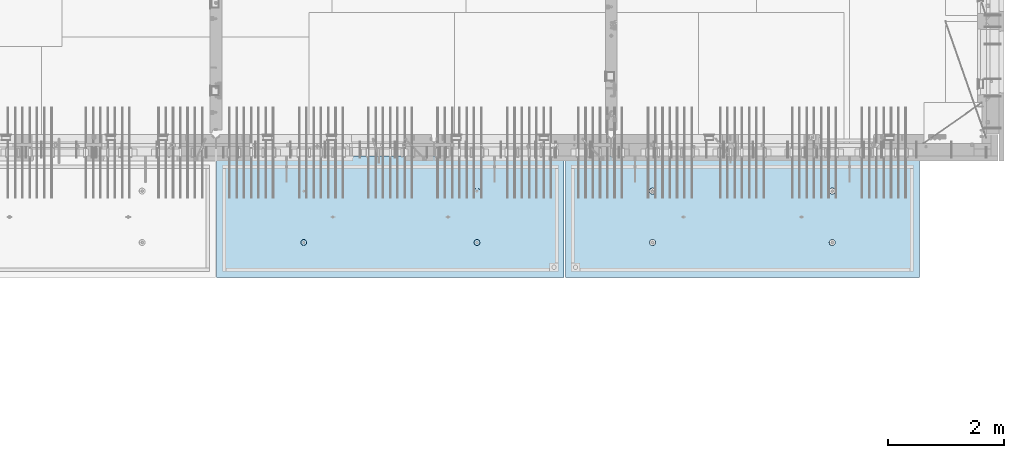
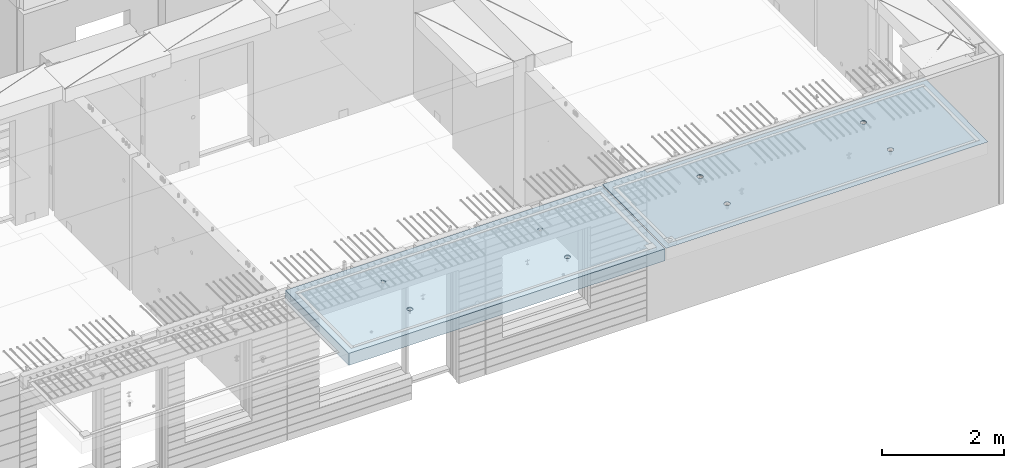
# One storey, part 195 of 334: 2 slabs, 2 elements without a shape of their own.
"""IFC2X3 building model written with IfcOpenShell, lengths in millimetres."""

from ifc_helpers import new_model, si_unit, frame, origin_with_axes, place, context, subcontext, project, spatial, faceted_brep, material, type_object, element, aggregate, save


model = new_model("IFC2X3")

# Units and contexts
model_context = context("Model", 3, precision=1e-05, world=origin_with_axes())
body_context = subcontext(model_context, "Body", "Model", "MODEL_VIEW")
ifc_project = project(units=[si_unit("LENGTHUNIT", "METRE", prefix="MILLI"), si_unit("AREAUNIT", "SQUARE_METRE"), si_unit("VOLUMEUNIT", "CUBIC_METRE"), si_unit("MASSUNIT", "GRAM", prefix="KILO"), si_unit("TIMEUNIT", "SECOND"), si_unit("PLANEANGLEUNIT", "RADIAN"), si_unit("SOLIDANGLEUNIT", "STERADIAN"), si_unit("THERMODYNAMICTEMPERATUREUNIT", "DEGREE_CELSIUS"), si_unit("LUMINOUSINTENSITYUNIT", "LUMEN")], contexts=[model_context])

# Site, building, storey
site_placement = place(None, origin_with_axes())
site = spatial("IfcSite", under=ifc_project, at=site_placement, CompositionType="ELEMENT")
building_placement = place(site_placement, origin_with_axes())
building = spatial("IfcBuilding", under=site, at=building_placement, CompositionType="ELEMENT")
storey_placement = place(building_placement, origin_with_axes())
storey = spatial("IfcBuildingStorey", under=building, at=storey_placement, Name="3", CompositionType="ELEMENT", Elevation=0.0)

# Assembly, slab
assembly_1_placement = place(storey_placement, origin_with_axes())
assembly_1 = element("IfcElementAssembly", 1, at=assembly_1_placement, inside=storey, AssemblyPlace="NOTDEFINED", PredefinedType="REINFORCEMENT_UNIT")
ifc_material = material(Name="CONCRETE/C35/45")
slab_type_1 = type_object("IfcSlabType", PredefinedType="NOTDEFINED")
slab_1_placement = place(assembly_1_placement, frame((33909.9998568133, 7629.99655735226, 90720.0), z_axis=(-1.11800000013248e-06, -0.999999999999375, 0.0), x_axis=(-0.999999999999093, 1.34699999998405e-06, 0.0)))
slab_1 = element("IfcSlab", 2, at=slab_1_placement, type_object=slab_type_1, material=ifc_material, PredefinedType="FLOOR", context=body_context, shape_type="Brep", body=[
    faceted_brep([(4540.5429407651, 4.39872694581572, 1501.06992058926), (4541.14829635528, 10.0, 1500.87322939105), (4548.44394652849, 10.0, 1515.19178906455), (4547.94177529477, 4.5376880098047, 1515.55663695519), (4559.80720044041, 10.0, 1526.55506865745), (4559.44971344555, 4.64790814399021, 1527.04710612474), (4574.1257436257, 10.0, 1533.85075119058), (4573.94028523447, 4.71864591048507, 1534.42153123348), (4589.99797731422, 10.0, 1536.36468442559), (4589.99797663917, 4.74301553473924, 1536.96206902392), (4605.87021668419, 10.0, 1533.85078706184), (4606.05567377324, 4.71864625823218, 1534.42156748629), (4620.18877635769, 10.0, 1526.55513688863), (4620.54626219634, 4.64790880566579, 1527.04717510301), (4631.55205595059, 10.0, 1515.19188297671), (4632.05422627598, 4.53768892097287, 1515.5567319414), (4638.84773848372, 10.0, 1500.87333979142), (4639.45309351355, 4.39872801757883, 1501.0700323201), (4641.36167171873, 10.0, 1485.0011061029), (4642.01569559209, 4.24458991442225, 1485.00110684195), (4638.84777435497, 10.0, 1469.12886673293), (4639.48645790269, 4.09034788147255, 1468.92134666652), (4631.55212418177, 10.0, 1454.81030705943), (4632.10822132771, 3.95111487063696, 1454.40627979329), (4620.18887026985, 10.0, 1443.44702746653), (4620.60028327593, 3.84055859092041, 1442.88076738872), (4605.87032708456, 10.0, 1436.1513449334), (4606.0891136727, 3.76954887632746, 1435.47799164192), (4589.99809339604, 10.0, 1433.63741169839), (4589.99809419923, 3.74507537655882, 1432.92662480936), (4574.12585402606, 10.0, 1436.15130906214), (4573.90706894744, 3.76954852712515, 1435.47795523847), (4559.80729435257, 10.0, 1443.44695923535), (4559.39588258188, 3.84055792690197, 1442.8806981667), (4548.44401475967, 10.0, 1454.81021314727), (4547.88791844284, 3.95111395715503, 1454.40618456334), (4541.14833222653, 10.0, 1469.12875633256), (4540.50964903182, 4.09034680826881, 1468.92123478504), (4538.63439899152, 10.0, 1485.00099002108), (4537.98037499001, 4.24458878673613, 1485.00098928203), (0.0, 10.0, 0.0), (0.0, -10.0, 0.0), (0.000819232023786753, 10.0, 2085.00366210937), (6090.0, 10.0, 1.39971234602854e-09), (6090.0, -10.0, 1.39971234602854e-09), (6090.0009765625, 10.0, 2085.00366210937), (1450.13343574908, -4.39996016312216, 583.805178487186), (1451.68970517172, 10.0, 584.310843019489), (1449.20358093267, 10.0, 600.007498901724), (1447.58488291994, -4.2445425120095, 600.007497072595), (1457.56794425657, -4.54025428339082, 569.17949076172), (1458.90468325205, 10.0, 570.15069079864), (1469.16362510388, -4.65165300057561, 557.566154097598), (1470.14226284945, 10.0, 558.913136598135), (1483.78541952188, -4.72320365252381, 550.106985529351), (1484.30243137612, 10.0, 551.698190519764), (1499.99909477071, -4.74786334385863, 547.536208193364), (1499.99909287695, 10.0, 549.212101755165), (1516.2127641972, -4.72320330067305, 550.107022210277), (1515.69574875919, 10.0, 551.698225994214), (1530.8345417251, -4.65165233150765, 557.566223847243), (1529.85590098004, 10.0, 558.913204074546), (1542.4301962863, -4.54025336292398, 569.179586717545), (1541.09345518054, 10.0, 570.150783671952), (1549.86467170747, -4.39995908172568, 583.805291221456), (1548.30840125891, 10.0, 584.310952198615), (1552.41318790712, -4.24454137573775, 600.00761552858), (1550.79449002351, 10.0, 600.007613699451), (1549.83105300624, -4.08922839167644, 616.199022553535), (1548.30836578447, 10.0, 615.704269581685), (1542.37578967018, -3.94920829200419, 630.796143582923), (1541.09338770413, 10.0, 629.864421802535), (1530.78010888273, -3.83814828256436, 642.374169903326), (1529.85580810672, 10.0, 641.101976003039), (1516.17906941009, -3.76687165064504, 649.804771831361), (1515.69563958006, 10.0, 648.316922081409), (1499.99897631459, -3.74231662515376, 652.364637735232), (1499.99897807923, 10.0, 650.803010846011), (1483.81888899212, -3.76687200104061, 649.804735302227), (1484.30232219699, 10.0, 648.316886606961), (1469.21786628045, -3.83814894927491, 642.374100399286), (1470.14216997614, 10.0, 641.101908526629), (1457.62221161949, -3.94920921009907, 630.796047872702), (1458.90461577564, 10.0, 629.864328929222), (1450.16698124064, -4.08922947161773, 616.198909971055), (1451.68966969727, 10.0, 615.704160402559), (1450.509655854, 4.09040925785666, 1468.92774521603), (1451.1483322995, 10.0, 1469.13526457059), (1448.63439906449, 10.0, 1485.00749825911), (1447.98038215714, 4.24465121529647, 1485.00749752007), (1457.88792425878, 3.95117642574769, 1454.41269697389), (1458.44401483263, 10.0, 1454.8167213853), (1469.39588682837, 3.84062041057041, 1442.8872121491), (1469.80729442553, 10.0, 1443.45346747338), (1483.90707121489, 3.76961102048517, 1435.48447023045), (1484.12585409903, 10.0, 1436.15781730018), (1499.99809427218, 3.74513787325122, 1432.93314014929), (1499.998093469, 10.0, 1433.64391993642), (1516.08911155117, 3.76961136968748, 1435.48450663389), (1515.87032715752, 10.0, 1436.15785317143), (1530.60027917537, 3.8406210745743, 1442.88728137111), (1530.18887034281, 10.0, 1443.45353570456), (1542.1082156577, 3.95117733922962, 1454.41279220383), (1541.55212425473, 10.0, 1454.81681529746), (1549.48645122644, 4.09041033107496, 1468.92785709749), (1548.84777442794, 10.0, 1469.13537497096), (1552.0156885709, 4.24465234298259, 1485.00761507997), (1551.3616717917, 10.0, 1485.00761434093), (1549.45308684185, 4.39879042512621, 1501.07653836665), (1548.84773855669, 10.0, 1500.87984802946), (1542.05422061333, 4.5377513095591, 1515.56323601226), (1541.55205602355, 10.0, 1515.19839121474), (1530.54625810314, 4.64797117923445, 1527.0536776068), (1530.18877643065, 10.0, 1526.56164512666), (1516.05567165627, 4.71870862215292, 1534.42806898436), (1515.87021675715, 10.0, 1533.85729529987), (1499.99797671215, 4.74307789534214, 1536.96857017552), (1499.99797738718, 10.0, 1536.37119266363), (1483.94028749739, 4.71870827439125, 1534.42803273156), (1484.12574369866, 10.0, 1533.85725942862), (1469.44971768469, 4.64797051755886, 1527.05360862854), (1469.80720051337, 10.0, 1526.56157689548), (1457.94178110336, 4.53775039840548, 1515.56314102606), (1458.44394660145, 10.0, 1515.19829730258), (1450.54294758273, 4.39878935334855, 1501.07642663582), (1451.14829642825, 10.0, 1500.87973762909), (4619.85580803376, 10.0, 641.095467765007), (4620.78011297592, -3.83821065611846, 642.367667399533), (4606.17907152706, -3.76693401455123, 649.798270333285), (4605.6956395071, 10.0, 648.310413843377), (4631.09338763116, 10.0, 629.857913564502), (4632.37579533283, -3.94927068060497, 630.789639512066), (4638.30836571149, 10.0, 615.697761343654), (4639.83105967794, -4.08929079922382, 616.192516506986), (4640.79448995054, 10.0, 600.001105461418), (4642.4131949283, -4.24460380429809, 600.001107290555), (4638.30840118594, 10.0, 584.304443960583), (4639.86467838373, -4.40002153132809, 583.798780790478), (4631.09345510758, 10.0, 570.14427543392), (4632.43020195632, -4.54031583151664, 569.173074307006), (4619.85590090707, 10.0, 558.906695836514), (4620.83454582566, -4.65171481517609, 557.559709864858), (4605.69574868622, 10.0, 551.691717756181), (4606.21276631872, -4.72326579401852, 550.100507218302), (4589.99909280399, 10.0, 549.205593517132), (4589.99909469776, -4.74792584055103, 547.529692853434), (4574.30243130315, 10.0, 551.691682281732), (4573.78541725442, -4.72326614588383, 550.10047053737), (4560.14226277649, 10.0, 558.906628360102), (4559.16362085739, -4.65171548424405, 557.559640115202), (4548.90468317908, 10.0, 570.144182560607), (4547.56793844064, -4.54031675198348, 569.172978351166), (4541.68970509875, 10.0, 584.304334781456), (4540.1334289269, -4.40002261272457, 583.798668056191), (4547.6222058109, -3.9492715986853, 630.789543801832), (4559.21786204131, -3.83821132282901, 642.367597895483), (4573.8188867292, -3.76693436496134, 649.798233804147), (4589.99897624161, -3.74237898574211, 652.358136583629), (4537.58487575281, -4.2446049405844, 600.000988834554), (4540.166974423, -4.0892918791651, 616.192403924491), (4589.99897800626, 10.0, 650.796502607977), (4574.30232212402, 10.0, 648.310378368928), (4560.14216990317, 10.0, 641.095400288596), (4548.90461570267, 10.0, 629.85782069119), (4541.6896696243, 10.0, 615.697652164527), (4539.2035808597, 10.0, 600.000990663691)], [[[0, 1, 2, 3]], [[3, 2, 4, 5]], [[5, 4, 6, 7]], [[8, 9, 7, 6]], [[10, 11, 9, 8]], [[12, 13, 11, 10]], [[14, 15, 13, 12]], [[16, 17, 15, 14]], [[18, 19, 17, 16]], [[20, 21, 19, 18]], [[22, 23, 21, 20]], [[24, 25, 23, 22]], [[25, 24, 26, 27]], [[27, 26, 28, 29]], [[29, 28, 30, 31]], [[31, 30, 32, 33]], [[33, 32, 34, 35]], [[35, 34, 36, 37]], [[37, 36, 38, 39]], [[39, 38, 1, 0]], [[40, 41, 42]], [[40, 43, 44, 41]], [[43, 45, 44]], [[46, 47, 48, 49]], [[50, 51, 47, 46]], [[52, 53, 51, 50]], [[54, 55, 53, 52]], [[56, 57, 55, 54]], [[58, 59, 57, 56]], [[59, 58, 60, 61]], [[61, 60, 62, 63]], [[63, 62, 64, 65]], [[65, 64, 66, 67]], [[67, 66, 68, 69]], [[69, 68, 70, 71]], [[71, 70, 72, 73]], [[73, 72, 74, 75]], [[75, 74, 76, 77]], [[78, 79, 77, 76]], [[80, 81, 79, 78]], [[82, 83, 81, 80]], [[84, 85, 83, 82]], [[49, 48, 85, 84]], [[86, 87, 88, 89]], [[90, 91, 87, 86]], [[92, 93, 91, 90]], [[94, 95, 93, 92]], [[96, 97, 95, 94]], [[98, 99, 97, 96]], [[100, 101, 99, 98]], [[101, 100, 102, 103]], [[103, 102, 104, 105]], [[105, 104, 106, 107]], [[107, 106, 108, 109]], [[109, 108, 110, 111]], [[111, 110, 112, 113]], [[113, 112, 114, 115]], [[115, 114, 116, 117]], [[117, 116, 118, 119]], [[120, 121, 119, 118]], [[122, 123, 121, 120]], [[124, 125, 123, 122]], [[89, 88, 125, 124]], [[126, 127, 128, 129]], [[130, 131, 127, 126]], [[132, 133, 131, 130]], [[134, 135, 133, 132]], [[136, 137, 135, 134]], [[138, 139, 137, 136]], [[140, 141, 139, 138]], [[142, 143, 141, 140]], [[143, 142, 144, 145]], [[145, 144, 146, 147]], [[147, 146, 148, 149]], [[149, 148, 150, 151]], [[151, 150, 152, 153]], [[41, 44, 45, 42], [3, 5, 7, 9, 11, 13, 15, 17, 19, 21, 23, 25, 27, 29, 31, 33, 35, 37, 39, 0], [154, 155, 156, 157, 128, 127, 131, 133, 135, 137, 139, 141, 143, 145, 147, 149, 151, 153, 158, 159], [122, 120, 118, 116, 114, 112, 110, 108, 106, 104, 102, 100, 98, 96, 94, 92, 90, 86, 89, 124], [82, 80, 78, 76, 74, 72, 70, 68, 66, 64, 62, 60, 58, 56, 54, 52, 50, 46, 49, 84]], [[129, 128, 157, 160]], [[156, 161, 160, 157]], [[155, 162, 161, 156]], [[154, 163, 162, 155]], [[159, 164, 163, 154]], [[158, 165, 164, 159]], [[153, 152, 165, 158]], [[43, 40, 42, 45], [34, 32, 30, 28, 26, 24, 22, 20, 18, 16, 14, 12, 10, 8, 6, 4, 2, 1, 38, 36], [150, 148, 146, 144, 142, 140, 138, 136, 134, 132, 130, 126, 129, 160, 161, 162, 163, 164, 165, 152], [91, 93, 95, 97, 99, 101, 103, 105, 107, 109, 111, 113, 115, 117, 119, 121, 123, 125, 88, 87], [51, 53, 55, 57, 59, 61, 63, 65, 67, 69, 71, 73, 75, 77, 79, 81, 83, 85, 48, 47]]]),
])
aggregate(assembly_1, [slab_1])

assembly_2_placement = place(storey_placement, origin_with_axes())
assembly_2 = element("IfcElementAssembly", 3, at=assembly_2_placement, inside=storey, AssemblyPlace="NOTDEFINED", PredefinedType="REINFORCEMENT_UNIT")
slab_type_2 = type_object("IfcSlabType", PredefinedType="NOTDEFINED")
slab_2_placement = place(assembly_2_placement, frame((27799.9998568133, 7629.99655735226, 90590.0), z_axis=(-1.11800000013248e-06, -0.999999999999375, 0.0), x_axis=(-0.999999999999093, 1.34699999998405e-06, 0.0)))
slab_2 = element("IfcSlab", 4, at=slab_2_placement, type_object=slab_type_2, material=ifc_material, PredefinedType="FLOOR", context=body_context, shape_type="Brep", body=[
    faceted_brep([(4464.54840508898, -115.0, 647.555217913627), (4450.61000036748, -115.0, 640.453225774507), (4439.54842599525, -115.0, 629.391625938503), (4432.44646594236, -115.0, 615.453204868262), (4429.99930954105, -115.0, 600.002352332828), (4432.44650151022, -115.0, 584.551505430789), (4439.54849364933, -115.0, 570.613100709295), (4450.61009348534, -115.0, 559.551526337066), (4464.54851455558, -115.0, 552.449566284174), (4479.99936709102, -115.0, 550.002409882861), (4495.45021399306, -115.0, 552.449601852029), (4509.38861871455, -115.0, 559.551593991148), (4520.45019308678, -115.0, 570.613193827152), (4527.55215313967, -115.0, 584.551614897394), (4529.99930954098, -115.0, 600.002467432828), (4527.55211757181, -115.0, 615.453314334867), (4520.4501254327, -115.0, 629.39171905636), (4509.38852559669, -115.0, 640.453293428589), (4495.45010452645, -115.0, 647.555253481482), (4479.99925199102, -115.0, 650.002409882794), (4439.08882528693, -120.0, 570.279131286869), (4431.90612869169, -120.0, 584.375926971106), (4450.27612512107, -120.0, 559.091857205865), (4464.37293733984, -120.0, 551.909193061462), (4479.99936774499, -120.0, 549.43422806468), (4495.62579245274, -120.0, 551.909229033498), (4509.72258813697, -120.0, 559.091925628744), (4520.90986221798, -120.0, 570.279225462882), (4528.09252636238, -120.0, 584.37603768165), (4530.56749135916, -120.0, 600.002468086805), (4528.09249039035, -120.0, 615.628892794549), (4520.9097937951, -120.0, 629.725688478787), (4509.72249396096, -120.0, 640.912962559792), (4495.6256817422, -120.0, 648.095626704194), (4479.99925133704, -120.0, 650.570591700976), (4464.3728266293, -120.0, 648.095590732158), (4450.27603094506, -120.0, 640.912894136913), (4439.08875686405, -120.0, 629.725594302773), (4431.90609271965, -120.0, 615.628782084005), (4429.43112772287, -120.0, 600.002351678851), (0.000819232023786753, -120.0, 2085.00366210938), (5980.0009765625, -120.0, 2085.00366210937), (5980.0009765625, 120.0, 2085.00366210937), (0.000819232023786753, 120.0, 2085.00366210938), (5980.0, -120.0, -2.4019755073823e-09), (5980.0, 120.0, -2.4019755073823e-09), (-7.27595761418343e-12, -120.0, -9.09494701772928e-13), (-7.27595761418343e-12, 120.0, -9.09494701772928e-13), (1515.44890870648, -105.0, 1437.44477976918), (1529.38731342797, -105.0, 1444.5467719083), (1540.4488878002, -105.0, 1455.60837174431), (1547.55084785309, -105.0, 1469.54679281455), (1549.99800425441, -105.0, 1484.99764534998), (1547.55081228524, -105.0, 1500.44849225202), (1540.44882014612, -105.0, 1514.38689697351), (1529.38722031012, -105.0, 1525.44847134574), (1515.44879923988, -105.0, 1532.55043139864), (1499.99794670444, -105.0, 1534.99758779995), (1484.5470998024, -105.0, 1532.55039583078), (1470.60869508091, -105.0, 1525.44840369166), (1459.54712070868, -105.0, 1514.38680385566), (1452.44516065579, -105.0, 1500.44838278542), (1449.99800425447, -105.0, 1484.99753024998), (1452.44519622364, -105.0, 1469.54668334794), (1459.54718836276, -105.0, 1455.60827862645), (1470.60878819877, -105.0, 1444.54670425422), (1484.547209269, -105.0, 1437.44474420133), (1499.99806180444, -105.0, 1434.99758780001), (1450.82407776805, -120.0, 1469.01994796889), (1448.29345879993, -120.0, 1484.99752828805), (1458.16818327555, -120.0, 1454.60637035917), (1469.60688310596, -120.0, 1443.16769686061), (1484.02047762178, -120.0, 1435.82362453319), (1499.99806376637, -120.0, 1433.29304234547), (1515.97564408552, -120.0, 1435.82366131359), (1530.38922169525, -120.0, 1443.16776682109), (1541.82789519381, -120.0, 1454.6064666515), (1549.17196752123, -120.0, 1469.02006116732), (1551.70254970895, -120.0, 1484.99764731191), (1549.17193074083, -120.0, 1500.97522763107), (1541.82782523334, -120.0, 1515.38880524079), (1530.38912540293, -120.0, 1526.82747873935), (1515.9755308871, -120.0, 1534.17155106677), (1499.99794474251, -120.0, 1536.70213325449), (1484.02036442336, -120.0, 1534.17151428637), (1469.60678681363, -120.0, 1526.82740877888), (1458.16811331507, -120.0, 1515.38870894846), (1450.82404098765, -120.0, 1500.97511443265), (1484.54840517324, -115.0, 647.55178787166), (1470.61000045175, -115.0, 640.44979573254), (1459.54842607952, -115.0, 629.388195896537), (1452.44646602663, -115.0, 615.449774826296), (1449.99930962532, -115.0, 599.998922290862), (1452.44650159449, -115.0, 584.548075388822), (1459.5484937336, -115.0, 570.609670667329), (1470.61009356961, -115.0, 559.5480962951), (1484.54851463985, -115.0, 552.446136242207), (1499.99936717528, -115.0, 549.998979840894), (1515.45021407733, -115.0, 552.446171810063), (1529.38861879882, -115.0, 559.548163949182), (1540.45019317105, -115.0, 570.609763785185), (1547.55215322394, -115.0, 584.548184855427), (1549.99930962525, -115.0, 599.999037390861), (1547.55211765608, -115.0, 615.449884292901), (1540.45012551697, -115.0, 629.388289014393), (1529.38852568096, -115.0, 640.449863386622), (1515.45010461072, -115.0, 647.551823439516), (1499.99925207528, -115.0, 649.998979840828), (1451.90612877595, -120.0, 584.37249692914), (1449.43112780714, -120.0, 599.998921636884), (1459.0888253712, -120.0, 570.275701244902), (1470.27612520534, -120.0, 559.088427163899), (1484.3729374241, -120.0, 551.905763019496), (1499.99936782926, -120.0, 549.430798022713), (1515.62579253701, -120.0, 551.905798991532), (1529.72258822124, -120.0, 559.088495586778), (1540.90986230225, -120.0, 570.275795420916), (1548.09252644665, -120.0, 584.372607639683), (1550.56749144343, -120.0, 599.999038044839), (1548.09249047462, -120.0, 615.625462752582), (1540.90979387937, -120.0, 629.72225843682), (1529.72249404523, -120.0, 640.909532517825), (1515.62568182647, -120.0, 648.092196662227), (1499.9992514213, -120.0, 650.56716165901), (1484.37282671356, -120.0, 648.092160690191), (1470.27603102933, -120.0, 640.909464094946), (1459.08875694832, -120.0, 629.722164260806), (1451.90609280392, -120.0, 615.625352042039), (4495.44890862221, -105.0, 1437.44820981115), (4509.3873133437, -105.0, 1444.55020195027), (4520.44888771593, -105.0, 1455.61180178627), (4527.55084776882, -105.0, 1469.55022285651), (4529.99800417014, -105.0, 1485.00107539195), (4527.55081220097, -105.0, 1500.45192229399), (4520.44882006185, -105.0, 1514.39032701548), (4509.38722022585, -105.0, 1525.45190138771), (4495.44879915561, -105.0, 1532.5538614406), (4479.99794662017, -105.0, 1535.00101784192), (4464.54709971813, -105.0, 1532.55382587275), (4450.60869499664, -105.0, 1525.45183373363), (4439.54712062441, -105.0, 1514.39023389763), (4432.44516057152, -105.0, 1500.45181282738), (4429.9980041702, -105.0, 1485.00096029195), (4432.44519613937, -105.0, 1469.55011338991), (4439.54718827849, -105.0, 1455.61170866842), (4450.6087881145, -105.0, 1444.55013429619), (4464.54720918474, -105.0, 1437.44817424329), (4479.99806172017, -105.0, 1435.00101784198), (4430.82407768378, -120.0, 1469.02337801086), (4428.29345871566, -120.0, 1485.00095833002), (4438.16818319128, -120.0, 1454.60980040114), (4449.60688302169, -120.0, 1443.17112690258), (4464.02047753751, -120.0, 1435.82705457516), (4479.99806368211, -120.0, 1433.29647238744), (4495.97564400126, -120.0, 1435.82709135556), (4510.38922161098, -120.0, 1443.17119686305), (4521.82789510954, -120.0, 1454.60989669347), (4529.17196743696, -120.0, 1469.02349120928), (4531.70254962468, -120.0, 1485.00107735388), (4529.17193065656, -120.0, 1500.97865767303), (4521.82782514907, -120.0, 1515.39223528276), (4510.38912531866, -120.0, 1526.83090878132), (4495.97553080284, -120.0, 1534.17498110874), (4479.99794465824, -120.0, 1536.70556329646), (4464.02036433909, -120.0, 1534.17494432834), (4449.60678672936, -120.0, 1526.83083882084), (4438.1681132308, -120.0, 1515.39213899043), (4430.82404090338, -120.0, 1500.97854447461)], [[[0, 1, 2, 3, 4, 5, 6, 7, 8, 9, 10, 11, 12, 13, 14, 15, 16, 17, 18, 19]], [[20, 6, 5, 21]], [[22, 7, 6, 20]], [[23, 8, 7, 22]], [[24, 9, 8, 23]], [[25, 10, 9, 24]], [[26, 11, 10, 25]], [[27, 12, 11, 26]], [[28, 13, 12, 27]], [[29, 14, 13, 28]], [[30, 15, 14, 29]], [[31, 16, 15, 30]], [[32, 17, 16, 31]], [[33, 18, 17, 32]], [[34, 19, 18, 33]], [[35, 0, 19, 34]], [[36, 1, 0, 35]], [[37, 2, 1, 36]], [[38, 3, 2, 37]], [[39, 4, 3, 38]], [[21, 5, 4, 39]], [[40, 41, 42, 43]], [[41, 44, 45, 42]], [[44, 46, 47, 45]], [[42, 45, 47, 43]], [[46, 40, 43, 47]], [[48, 49, 50, 51, 52, 53, 54, 55, 56, 57, 58, 59, 60, 61, 62, 63, 64, 65, 66, 67]], [[68, 63, 62, 69]], [[70, 64, 63, 68]], [[71, 65, 64, 70]], [[72, 66, 65, 71]], [[73, 67, 66, 72]], [[74, 48, 67, 73]], [[75, 49, 48, 74]], [[76, 50, 49, 75]], [[77, 51, 50, 76]], [[78, 52, 51, 77]], [[79, 53, 52, 78]], [[80, 54, 53, 79]], [[81, 55, 54, 80]], [[82, 56, 55, 81]], [[83, 57, 56, 82]], [[84, 58, 57, 83]], [[85, 59, 58, 84]], [[86, 60, 59, 85]], [[87, 61, 60, 86]], [[69, 62, 61, 87]], [[88, 89, 90, 91, 92, 93, 94, 95, 96, 97, 98, 99, 100, 101, 102, 103, 104, 105, 106, 107]], [[108, 93, 92, 109]], [[110, 94, 93, 108]], [[111, 95, 94, 110]], [[112, 96, 95, 111]], [[113, 97, 96, 112]], [[114, 98, 97, 113]], [[115, 99, 98, 114]], [[116, 100, 99, 115]], [[117, 101, 100, 116]], [[118, 102, 101, 117]], [[119, 103, 102, 118]], [[120, 104, 103, 119]], [[121, 105, 104, 120]], [[122, 106, 105, 121]], [[123, 107, 106, 122]], [[124, 88, 107, 123]], [[125, 89, 88, 124]], [[126, 90, 89, 125]], [[127, 91, 90, 126]], [[109, 92, 91, 127]], [[128, 129, 130, 131, 132, 133, 134, 135, 136, 137, 138, 139, 140, 141, 142, 143, 144, 145, 146, 147]], [[148, 143, 142, 149]], [[150, 144, 143, 148]], [[151, 145, 144, 150]], [[152, 146, 145, 151]], [[153, 147, 146, 152]], [[154, 128, 147, 153]], [[155, 129, 128, 154]], [[156, 130, 129, 155]], [[157, 131, 130, 156]], [[158, 132, 131, 157]], [[159, 133, 132, 158]], [[160, 134, 133, 159]], [[161, 135, 134, 160]], [[162, 136, 135, 161]], [[163, 137, 136, 162]], [[164, 138, 137, 163]], [[165, 139, 138, 164]], [[166, 140, 139, 165]], [[167, 141, 140, 166]], [[149, 142, 141, 167]], [[44, 41, 40, 46], [37, 36, 35, 34, 33, 32, 31, 30, 29, 28, 27, 26, 25, 24, 23, 22, 20, 21, 39, 38], [166, 165, 164, 163, 162, 161, 160, 159, 158, 157, 156, 155, 154, 153, 152, 151, 150, 148, 149, 167], [126, 125, 124, 123, 122, 121, 120, 119, 118, 117, 116, 115, 114, 113, 112, 111, 110, 108, 109, 127], [86, 85, 84, 83, 82, 81, 80, 79, 78, 77, 76, 75, 74, 73, 72, 71, 70, 68, 69, 87]]]),
])
aggregate(assembly_2, [slab_2])

save(model, "model.ifc")
